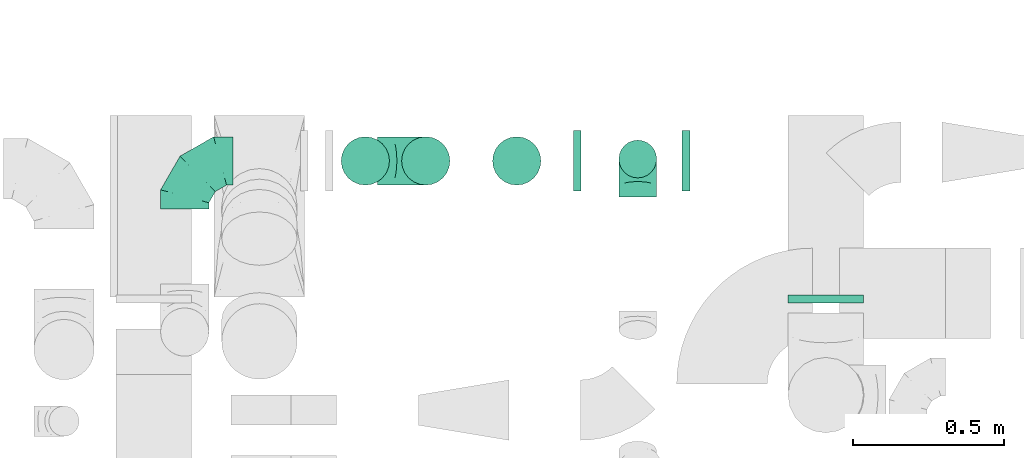
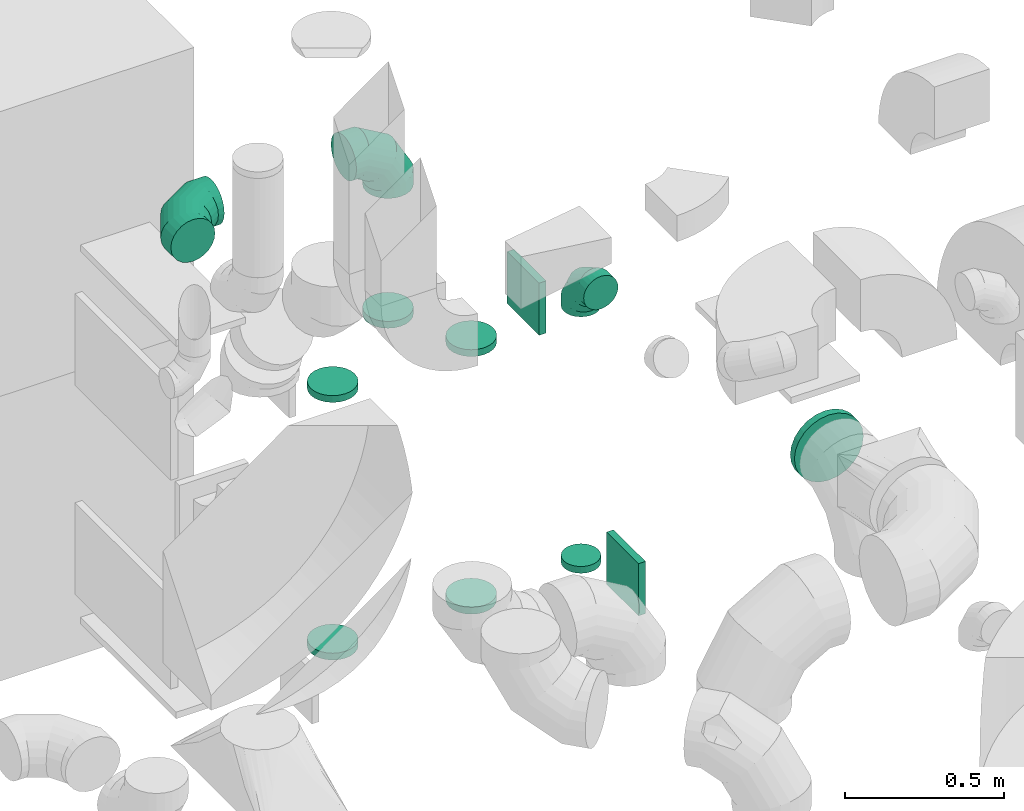
# One storey, part 29 of 59: 12 flow fittings.
"""IFC2X3 building model written with IfcOpenShell, lengths in millimetres."""

from ifc_helpers import new_model, entity, si_unit, converted_unit, derived_unit, direction, frame, origin, origin_2d_with_axis, place, context, subcontext, project, spatial, rectangle, extrude, faceted_brep, source, transform, mapped, material, type_object, type_shapes, element, save


model = new_model("IFC2X3")

# Units and contexts
model_context = context("Model", 3, precision=0.01, world=origin(), true_north=direction((6.12303176911189e-17, 1.0)))
body_context = subcontext(model_context, "Body", "Model", "MODEL_VIEW")
ifc_project = project(units=[si_unit("LENGTHUNIT", "METRE", prefix="MILLI"), si_unit("AREAUNIT", "SQUARE_METRE"), si_unit("VOLUMEUNIT", "CUBIC_METRE"), converted_unit("PLANEANGLEUNIT", "DEGREE", entity("IfcRatioMeasure", 0.0174532925199433), si_unit("PLANEANGLEUNIT", "RADIAN"), dimensions=[0, 0, 0, 0, 0, 0, 0]), si_unit("MASSUNIT", "GRAM", prefix="KILO"), derived_unit("MASSDENSITYUNIT", [(si_unit("MASSUNIT", "GRAM", prefix="KILO"), 1), (si_unit("LENGTHUNIT", "METRE"), -3)]), derived_unit("MOMENTOFINERTIAUNIT", [(si_unit("LENGTHUNIT", "METRE"), 4)]), si_unit("TIMEUNIT", "SECOND"), si_unit("FREQUENCYUNIT", "HERTZ"), si_unit("THERMODYNAMICTEMPERATUREUNIT", "DEGREE_CELSIUS"), derived_unit("THERMALTRANSMITTANCEUNIT", [(si_unit("MASSUNIT", "GRAM", prefix="KILO"), 1), (si_unit("THERMODYNAMICTEMPERATUREUNIT", "KELVIN"), -1), (si_unit("TIMEUNIT", "SECOND"), -3)]), derived_unit("VOLUMETRICFLOWRATEUNIT", [(si_unit("LENGTHUNIT", "METRE"), 3), (si_unit("TIMEUNIT", "SECOND"), -1)]), derived_unit("MASSFLOWRATEUNIT", [(si_unit("MASSUNIT", "GRAM", prefix="KILO"), 1), (si_unit("TIMEUNIT", "SECOND"), -1)]), derived_unit("ROTATIONALFREQUENCYUNIT", [(si_unit("TIMEUNIT", "SECOND"), -1)]), si_unit("ELECTRICCURRENTUNIT", "AMPERE"), si_unit("ELECTRICVOLTAGEUNIT", "VOLT"), si_unit("POWERUNIT", "WATT"), si_unit("FORCEUNIT", "NEWTON", prefix="KILO"), si_unit("ILLUMINANCEUNIT", "LUX"), si_unit("LUMINOUSFLUXUNIT", "LUMEN"), si_unit("LUMINOUSINTENSITYUNIT", "CANDELA"), derived_unit("USERDEFINED", [(si_unit("MASSUNIT", "GRAM", prefix="KILO"), -1), (si_unit("LENGTHUNIT", "METRE"), -2), (si_unit("TIMEUNIT", "SECOND"), 3), (si_unit("LUMINOUSFLUXUNIT", "LUMEN"), 1)]), derived_unit("LINEARVELOCITYUNIT", [(si_unit("LENGTHUNIT", "METRE"), 1), (si_unit("TIMEUNIT", "SECOND"), -1)]), si_unit("PRESSUREUNIT", "PASCAL"), derived_unit("USERDEFINED", [(si_unit("LENGTHUNIT", "METRE"), -2), (si_unit("MASSUNIT", "GRAM", prefix="KILO"), 1), (si_unit("TIMEUNIT", "SECOND"), -2)]), derived_unit("LINEARFORCEUNIT", [(si_unit("MASSUNIT", "GRAM", prefix="KILO"), 1), (si_unit("LENGTHUNIT", "METRE"), 1), (si_unit("TIMEUNIT", "SECOND"), -2), (si_unit("LENGTHUNIT", "METRE"), -1)]), derived_unit("PLANARFORCEUNIT", [(si_unit("MASSUNIT", "GRAM", prefix="KILO"), 1), (si_unit("LENGTHUNIT", "METRE"), 1), (si_unit("TIMEUNIT", "SECOND"), -2), (si_unit("LENGTHUNIT", "METRE"), -2)])], contexts=[model_context])

# Site, building, storey
site_placement = place(None, origin())
site = spatial("IfcSite", under=ifc_project, at=site_placement, CompositionType="ELEMENT")
building_placement = place(site_placement, origin())
building = spatial("IfcBuilding", under=site, at=building_placement, CompositionType="ELEMENT")
storey_placement = place(building_placement, frame((0.0, 0.0, 28200.0)))
storey = spatial("IfcBuildingStorey", under=building, at=storey_placement, CompositionType="ELEMENT", Elevation=28200.0)

# Flow fittings
ifc_material = material()
duct_fitting_type_1 = type_object("IfcDuctFittingType", PredefinedType="NOTDEFINED", material=ifc_material)
shared_shape_1 = source(origin(), body_context, "Body", "SweptSolid", [
    extrude(rectangle(XDim=24.9999999999999, YDim=200.0, at=origin_2d_with_axis()), frame((12.5, 0.0, -100.0)), (0.0, 0.0, 1.0), 200.0),
])
type_shapes(duct_fitting_type_1, [shared_shape_1])
for number, where in (
    (1, (50418.28, 13024.99, 1699.32)),
    (2, (50058.28, 13024.99, 2899.32)),
):
    element("IfcFlowFitting", number, at=place(storey_placement, frame(where)), inside=storey, type_object=duct_fitting_type_1, material=ifc_material, context=body_context, shape_type="MappedRepresentation", body=[
        mapped(shared_shape_1, transform((0.0, 0.0, 0.0), scale=1.0)),
    ])
duct_fitting_type_2 = type_object("IfcDuctFittingType", PredefinedType="NOTDEFINED", material=ifc_material)
shared_shape_2 = source(origin(), body_context, "Body", "Brep", [
    faceted_brep([(-160.0, 0.0, -80.0), (-160.0, -20.71, -77.27), (-160.0, -40.0, -69.28), (-160.0, -56.57, -56.57), (-160.0, -69.28, -40.0), (-160.0, -77.27, -20.71), (-160.0, -80.0, 0.0), (-160.0, -77.27, 20.71), (-160.0, -69.28, 40.0), (-160.0, -56.57, 56.57), (-160.0, -40.0, 69.28), (-160.0, -20.71, 77.27), (-160.0, 0.0, 80.0), (-160.0, 20.71, 77.27), (-160.0, 40.0, 69.28), (-160.0, 56.57, 56.57), (-160.0, 69.28, 40.0), (-160.0, 77.27, 20.71), (-160.0, 80.0, 0.0), (-160.0, 77.27, -20.71), (-160.0, 69.28, -40.0), (-160.0, 56.57, -56.57), (-160.0, 40.0, -69.28), (-160.0, 20.71, -77.27), (-122.68, 20.71, 77.27), (-127.85, 40.0, 69.28), (-117.13, 0.0, 80.0), (-132.29, 56.57, 56.57), (-137.83, 77.27, 20.71), (-138.56, 80.0, 0.0), (-135.69, 69.28, 40.0), (-135.69, 69.28, -40.0), (-132.29, 56.57, -56.57), (-137.83, 77.27, -20.71), (-122.68, 20.71, -77.27), (-117.13, 0.0, -80.0), (-127.85, 40.0, -69.28), (-111.58, -20.71, -77.27), (-106.41, -40.0, -69.28), (-101.97, -56.57, -56.57), (-98.56, -69.28, -40.0), (-96.42, -77.27, -20.71), (-95.69, -80.0, 0.0), (-96.42, -77.27, 20.71), (-98.56, -69.28, 40.0), (-101.97, -56.57, 56.57), (-106.41, -40.0, 69.28), (-111.58, -20.71, 77.27), (-58.03, 58.03, 77.27), (-72.15, 72.15, 69.28), (-42.87, 42.87, 80.0), (-84.28, 84.28, 56.57), (-93.59, 93.59, 40.0), (-99.44, 99.44, 20.71), (-101.44, 101.44, 0.0), (-99.44, 99.44, -20.71), (-93.59, 93.59, -40.0), (-84.28, 84.28, -56.57), (-58.03, 58.03, -77.27), (-42.87, 42.87, -80.0), (-72.15, 72.15, -69.28), (-27.71, 27.71, -77.27), (-13.59, 13.59, -69.28), (-1.46, 1.46, -56.57), (7.85, -7.85, -40.0), (13.7, -13.7, -20.71), (15.69, -15.69, 0.0), (13.7, -13.7, 20.71), (7.85, -7.85, 40.0), (-1.46, 1.46, 56.57), (-13.59, 13.59, 69.28), (-27.71, 27.71, 77.27), (-20.71, 122.68, 77.27), (-40.0, 127.85, 69.28), (0.0, 117.13, 80.0), (-56.57, 132.29, 56.57), (-69.28, 135.69, 40.0), (-77.27, 137.83, 20.71), (-80.0, 138.56, 0.0), (-77.27, 137.83, -20.71), (-69.28, 135.69, -40.0), (-56.57, 132.29, -56.57), (-20.71, 122.68, -77.27), (0.0, 117.13, -80.0), (-40.0, 127.85, -69.28), (20.71, 111.58, -77.27), (40.0, 106.41, -69.28), (56.57, 101.97, -56.57), (69.28, 98.56, -40.0), (77.27, 96.42, -20.71), (80.0, 95.69, 0.0), (77.27, 96.42, 20.71), (69.28, 98.56, 40.0), (56.57, 101.97, 56.57), (40.0, 106.41, 69.28), (20.71, 111.58, 77.27), (-20.71, 160.0, -77.27), (-40.0, 160.0, -69.28), (-56.57, 160.0, -56.57), (-69.28, 160.0, -40.0), (-77.27, 160.0, -20.71), (-80.0, 160.0, 0.0), (-77.27, 160.0, 20.71), (-69.28, 160.0, 40.0), (-56.57, 160.0, 56.57), (-40.0, 160.0, 69.28), (-20.71, 160.0, 77.27), (0.0, 160.0, 80.0), (20.71, 160.0, 77.27), (40.0, 160.0, 69.28), (56.57, 160.0, 56.57), (69.28, 160.0, 40.0), (77.27, 160.0, 20.71), (80.0, 160.0, 0.0), (77.27, 160.0, -20.71), (69.28, 160.0, -40.0), (56.57, 160.0, -56.57), (40.0, 160.0, -69.28), (20.71, 160.0, -77.27), (0.0, 160.0, -80.0)], [[[0, 1, 2, 3, 4, 5, 6, 7, 8, 9, 10, 11, 12, 13, 14, 15, 16, 17, 18, 19, 20, 21, 22, 23]], [[24, 25, 14, 13]], [[26, 24, 13, 12]], [[14, 25, 27, 15]], [[28, 29, 18, 17]], [[30, 28, 17, 16]], [[15, 27, 30, 16]], [[20, 31, 32, 21]], [[33, 31, 20, 19]], [[18, 29, 33, 19]], [[34, 35, 0, 23]], [[36, 34, 23, 22]], [[32, 36, 22, 21]], [[1, 0, 35, 37]], [[2, 1, 37, 38]], [[3, 2, 38, 39]], [[5, 4, 40, 41]], [[6, 5, 41, 42]], [[39, 40, 4, 3]], [[6, 42, 43, 7]], [[7, 43, 44, 8]], [[8, 44, 45, 9]], [[9, 45, 46, 10]], [[10, 46, 47, 11]], [[26, 12, 11, 47]], [[48, 49, 25, 24]], [[50, 48, 24, 26]], [[27, 25, 49, 51]], [[52, 53, 28, 30]], [[51, 52, 30, 27]], [[29, 28, 53, 54]], [[55, 56, 31, 33]], [[54, 55, 33, 29]], [[32, 31, 56, 57]], [[58, 59, 35, 34]], [[60, 58, 34, 36]], [[57, 60, 36, 32]], [[37, 35, 59, 61]], [[38, 37, 61, 62]], [[39, 38, 62, 63]], [[41, 40, 64, 65]], [[42, 41, 65, 66]], [[63, 64, 40, 39]], [[43, 42, 66, 67]], [[44, 43, 67, 68]], [[68, 69, 45, 44]], [[46, 45, 69, 70]], [[47, 46, 70, 71]], [[26, 47, 71, 50]], [[72, 73, 49, 48]], [[74, 72, 48, 50]], [[51, 49, 73, 75]], [[76, 77, 53, 52]], [[75, 76, 52, 51]], [[54, 53, 77, 78]], [[79, 80, 56, 55]], [[78, 79, 55, 54]], [[57, 56, 80, 81]], [[82, 83, 59, 58]], [[84, 82, 58, 60]], [[81, 84, 60, 57]], [[61, 59, 83, 85]], [[62, 61, 85, 86]], [[63, 62, 86, 87]], [[65, 64, 88, 89]], [[66, 65, 89, 90]], [[87, 88, 64, 63]], [[67, 66, 90, 91]], [[68, 67, 91, 92]], [[92, 93, 69, 68]], [[70, 69, 93, 94]], [[71, 70, 94, 95]], [[50, 71, 95, 74]], [[96, 97, 98, 99, 100, 101, 102, 103, 104, 105, 106, 107, 108, 109, 110, 111, 112, 113, 114, 115, 116, 117, 118, 119]], [[72, 74, 107, 106]], [[73, 72, 106, 105]], [[75, 73, 105, 104]], [[77, 76, 103, 102]], [[78, 77, 102, 101]], [[75, 104, 103, 76]], [[78, 101, 100, 79]], [[79, 100, 99, 80]], [[80, 99, 98, 81]], [[84, 97, 96, 82]], [[82, 96, 119, 83]], [[84, 81, 98, 97]], [[118, 117, 86, 85]], [[119, 118, 85, 83]], [[116, 87, 86, 117]], [[88, 115, 114, 89]], [[89, 114, 113, 90]], [[115, 88, 87, 116]], [[112, 111, 92, 91]], [[113, 112, 91, 90]], [[111, 110, 93, 92]], [[95, 94, 109, 108]], [[74, 95, 108, 107]], [[110, 109, 94, 93]]]),
])
type_shapes(duct_fitting_type_2, [shared_shape_2])
for number, where, z_axis, x_axis in (
    (3, (49568.63, 13024.99, 3650.0), (0.0, -1.0, 0.0), (0.0, 0.0, 1.0)),
    (4, (48770.09, 13024.99, 3650.0), (0.0, 0.0, 1.0), (-1.0, 0.0, 0.0)),
):
    element("IfcFlowFitting", number, at=place(storey_placement, frame(where, z_axis=z_axis, x_axis=x_axis)), inside=storey, type_object=duct_fitting_type_2, material=ifc_material, context=body_context, shape_type="MappedRepresentation", body=[
        mapped(shared_shape_2, transform((0.0, 0.0, 0.0), scale=1.0)),
    ])
duct_fitting_type_3 = type_object("IfcDuctFittingType", PredefinedType="NOTDEFINED", material=ifc_material)
shared_shape_3 = source(origin(), body_context, "Body", "Brep", [
    faceted_brep([(20.0, 0.0, -125.0), (20.0, 32.35, -120.74), (20.0, 62.5, -108.25), (20.0, 88.39, -88.39), (20.0, 108.25, -62.5), (20.0, 120.74, -32.35), (20.0, 125.0, 0.0), (20.0, 120.74, 32.35), (20.0, 108.25, 62.5), (20.0, 88.39, 88.39), (20.0, 62.5, 108.25), (20.0, 32.35, 120.74), (20.0, 0.0, 125.0), (20.0, -32.35, 120.74), (20.0, -62.5, 108.25), (20.0, -88.39, 88.39), (20.0, -108.25, 62.5), (20.0, -120.74, 32.35), (20.0, -125.0, 0.0), (20.0, -120.74, -32.35), (20.0, -108.25, -62.5), (20.0, -88.39, -88.39), (20.0, -62.5, -108.25), (20.0, -32.35, -120.74), (0.0, 0.0, 125.0), (-6.1, 0.0, 125.0), (-6.1, -32.35, 120.74), (0.0, -32.35, 120.74), (-6.1, -62.5, 108.25), (0.0, -62.5, 108.25), (0.0, -88.39, 88.39), (-6.1, -88.39, 88.39), (0.0, -108.25, 62.5), (-6.1, -108.25, 62.5), (-6.1, -120.74, 32.35), (0.0, -120.74, 32.35), (-6.1, -125.0, 0.0), (0.0, -125.0, 0.0), (-6.1, -120.74, -32.35), (0.0, -120.74, -32.35), (-6.1, -108.25, -62.5), (0.0, -108.25, -62.5), (0.0, -88.39, -88.39), (-6.1, -88.39, -88.39), (0.0, -62.5, -108.25), (-6.1, -62.5, -108.25), (-6.1, -32.35, -120.74), (0.0, -32.35, -120.74), (-6.1, 0.0, -125.0), (0.0, 0.0, -125.0), (-6.1, 32.35, -120.74), (0.0, 32.35, -120.74), (-6.1, 62.5, -108.25), (0.0, 62.5, -108.25), (0.0, 88.39, -88.39), (-6.1, 88.39, -88.39), (0.0, 108.25, -62.5), (-6.1, 108.25, -62.5), (-6.1, 120.74, -32.35), (0.0, 120.74, -32.35), (-6.1, 125.0, 0.0), (0.0, 125.0, 0.0), (-6.1, 120.74, 32.35), (0.0, 120.74, 32.35), (-6.1, 108.25, 62.5), (0.0, 108.25, 62.5), (0.0, 88.39, 88.39), (-6.1, 88.39, 88.39), (0.0, 62.5, 108.25), (-6.1, 62.5, 108.25), (-6.1, 32.35, 120.74), (0.0, 32.35, 120.74)], [[[0, 1, 2, 3, 4, 5, 6, 7, 8, 9, 10, 11, 12, 13, 14, 15, 16, 17, 18, 19, 20, 21, 22, 23]], [[13, 12, 24, 25, 26, 27]], [[14, 13, 27, 26, 28, 29]], [[30, 15, 14, 29, 28, 31]], [[17, 16, 32, 33, 34, 35]], [[18, 17, 35, 34, 36, 37]], [[32, 16, 15, 30, 31, 33]], [[19, 18, 37, 36, 38, 39]], [[20, 19, 39, 38, 40, 41]], [[42, 21, 20, 41, 40, 43]], [[23, 22, 44, 45, 46, 47]], [[0, 23, 47, 46, 48, 49]], [[44, 22, 21, 42, 43, 45]], [[1, 0, 49, 48, 50, 51]], [[2, 1, 51, 50, 52, 53]], [[54, 3, 2, 53, 52, 55]], [[5, 4, 56, 57, 58, 59]], [[6, 5, 59, 58, 60, 61]], [[56, 4, 3, 54, 55, 57]], [[7, 6, 61, 60, 62, 63]], [[8, 7, 63, 62, 64, 65]], [[66, 9, 8, 65, 64, 67]], [[11, 10, 68, 69, 70, 71]], [[12, 11, 71, 70, 25, 24]], [[68, 10, 9, 66, 67, 69]], [[46, 45, 43, 40, 38, 36, 34, 33, 31, 28, 26, 25, 70, 69, 67, 64, 62, 60, 58, 57, 55, 52, 50, 48]]]),
])
type_shapes(duct_fitting_type_3, [shared_shape_3])
flow_fitting_1_placement = place(storey_placement, frame((50893.68, 12574.75, 2302.02), z_axis=(-1.0, 0.0, 0.0), x_axis=(0.0, -1.0, 0.0)))
element("IfcFlowFitting", 5, at=flow_fitting_1_placement, inside=storey, type_object=duct_fitting_type_3, material=ifc_material, context=body_context, shape_type="MappedRepresentation", body=[
    mapped(shared_shape_3, transform((0.0, 0.0, 0.0), scale=1.0)),
])
duct_fitting_type_4 = type_object("IfcDuctFittingType", PredefinedType="NOTDEFINED", material=ifc_material)
shared_shape_4 = source(origin(), body_context, "Body", "Brep", [
    faceted_brep([(-125.0, 0.0, -62.5), (-125.0, -16.18, -60.37), (-125.0, -31.25, -54.13), (-125.0, -44.19, -44.19), (-125.0, -54.13, -31.25), (-125.0, -60.37, -16.18), (-125.0, -62.5, 0.0), (-125.0, -60.37, 16.18), (-125.0, -54.13, 31.25), (-125.0, -44.19, 44.19), (-125.0, -31.25, 54.13), (-125.0, -16.18, 60.37), (-125.0, 0.0, 62.5), (-125.0, 16.18, 60.37), (-125.0, 31.25, 54.13), (-125.0, 44.19, 44.19), (-125.0, 54.13, 31.25), (-125.0, 60.37, 16.18), (-125.0, 62.5, 0.0), (-125.0, 60.37, -16.18), (-125.0, 54.13, -31.25), (-125.0, 44.19, -44.19), (-125.0, 31.25, -54.13), (-125.0, 16.18, -60.37), (-95.84, 16.18, 60.37), (-99.88, 31.25, 54.13), (-91.51, 0.0, 62.5), (-103.35, 44.19, 44.19), (-107.68, 60.37, 16.18), (-108.25, 62.5, 0.0), (-106.01, 54.13, 31.25), (-106.01, 54.13, -31.25), (-103.35, 44.19, -44.19), (-107.68, 60.37, -16.18), (-95.84, 16.18, -60.37), (-91.51, 0.0, -62.5), (-99.88, 31.25, -54.13), (-87.17, -16.18, -60.37), (-83.13, -31.25, -54.13), (-79.66, -44.19, -44.19), (-77.0, -54.13, -31.25), (-75.33, -60.37, -16.18), (-74.76, -62.5, 0.0), (-75.33, -60.37, 16.18), (-77.0, -54.13, 31.25), (-79.66, -44.19, 44.19), (-83.13, -31.25, 54.13), (-87.17, -16.18, 60.37), (-45.34, 45.34, 60.37), (-56.37, 56.37, 54.13), (-33.49, 33.49, 62.5), (-65.85, 65.85, 44.19), (-73.12, 73.12, 31.25), (-77.69, 77.69, 16.18), (-79.25, 79.25, 0.0), (-77.69, 77.69, -16.18), (-73.12, 73.12, -31.25), (-65.85, 65.85, -44.19), (-45.34, 45.34, -60.37), (-33.49, 33.49, -62.5), (-56.37, 56.37, -54.13), (-21.65, 21.65, -60.37), (-10.62, 10.62, -54.13), (-1.14, 1.14, -44.19), (6.13, -6.13, -31.25), (10.7, -10.7, -16.18), (12.26, -12.26, 0.0), (10.7, -10.7, 16.18), (6.13, -6.13, 31.25), (-1.14, 1.14, 44.19), (-10.62, 10.62, 54.13), (-21.65, 21.65, 60.37), (-16.18, 95.84, 60.37), (-31.25, 99.88, 54.13), (0.0, 91.51, 62.5), (-44.19, 103.35, 44.19), (-54.13, 106.01, 31.25), (-60.37, 107.68, 16.18), (-62.5, 108.25, 0.0), (-60.37, 107.68, -16.18), (-54.13, 106.01, -31.25), (-44.19, 103.35, -44.19), (-16.18, 95.84, -60.37), (0.0, 91.51, -62.5), (-31.25, 99.88, -54.13), (16.18, 87.17, -60.37), (31.25, 83.13, -54.13), (44.19, 79.66, -44.19), (54.13, 77.0, -31.25), (60.37, 75.33, -16.18), (62.5, 74.76, 0.0), (60.37, 75.33, 16.18), (54.13, 77.0, 31.25), (44.19, 79.66, 44.19), (31.25, 83.13, 54.13), (16.18, 87.17, 60.37), (-16.18, 125.0, -60.37), (-31.25, 125.0, -54.13), (-44.19, 125.0, -44.19), (-54.13, 125.0, -31.25), (-60.37, 125.0, -16.18), (-62.5, 125.0, 0.0), (-60.37, 125.0, 16.18), (-54.13, 125.0, 31.25), (-44.19, 125.0, 44.19), (-31.25, 125.0, 54.13), (-16.18, 125.0, 60.37), (0.0, 125.0, 62.5), (16.18, 125.0, 60.37), (31.25, 125.0, 54.13), (44.19, 125.0, 44.19), (54.13, 125.0, 31.25), (60.37, 125.0, 16.18), (62.5, 125.0, 0.0), (60.37, 125.0, -16.18), (54.13, 125.0, -31.25), (44.19, 125.0, -44.19), (31.25, 125.0, -54.13), (16.18, 125.0, -60.37), (0.0, 125.0, -62.5)], [[[0, 1, 2, 3, 4, 5, 6, 7, 8, 9, 10, 11, 12, 13, 14, 15, 16, 17, 18, 19, 20, 21, 22, 23]], [[24, 25, 14, 13]], [[26, 24, 13, 12]], [[14, 25, 27, 15]], [[28, 29, 18, 17]], [[30, 28, 17, 16]], [[15, 27, 30, 16]], [[20, 31, 32, 21]], [[33, 31, 20, 19]], [[18, 29, 33, 19]], [[34, 35, 0, 23]], [[36, 34, 23, 22]], [[21, 32, 36, 22]], [[1, 0, 35, 37]], [[2, 1, 37, 38]], [[38, 39, 3, 2]], [[5, 4, 40, 41]], [[6, 5, 41, 42]], [[39, 40, 4, 3]], [[6, 42, 43, 7]], [[7, 43, 44, 8]], [[45, 9, 8, 44]], [[9, 45, 46, 10]], [[10, 46, 47, 11]], [[26, 12, 11, 47]], [[48, 49, 25, 24]], [[50, 48, 24, 26]], [[27, 25, 49, 51]], [[52, 53, 28, 30]], [[51, 52, 30, 27]], [[29, 28, 53, 54]], [[55, 56, 31, 33]], [[54, 55, 33, 29]], [[57, 32, 31, 56]], [[58, 59, 35, 34]], [[60, 58, 34, 36]], [[57, 60, 36, 32]], [[37, 35, 59, 61]], [[38, 37, 61, 62]], [[39, 38, 62, 63]], [[41, 40, 64, 65]], [[42, 41, 65, 66]], [[63, 64, 40, 39]], [[43, 42, 66, 67]], [[44, 43, 67, 68]], [[68, 69, 45, 44]], [[46, 45, 69, 70]], [[47, 46, 70, 71]], [[26, 47, 71, 50]], [[72, 73, 49, 48]], [[74, 72, 48, 50]], [[51, 49, 73, 75]], [[76, 77, 53, 52]], [[75, 76, 52, 51]], [[54, 53, 77, 78]], [[79, 80, 56, 55]], [[78, 79, 55, 54]], [[81, 57, 56, 80]], [[82, 83, 59, 58]], [[84, 82, 58, 60]], [[81, 84, 60, 57]], [[61, 59, 83, 85]], [[62, 61, 85, 86]], [[63, 62, 86, 87]], [[65, 64, 88, 89]], [[66, 65, 89, 90]], [[87, 88, 64, 63]], [[67, 66, 90, 91]], [[68, 67, 91, 92]], [[92, 93, 69, 68]], [[70, 69, 93, 94]], [[71, 70, 94, 95]], [[50, 71, 95, 74]], [[96, 97, 98, 99, 100, 101, 102, 103, 104, 105, 106, 107, 108, 109, 110, 111, 112, 113, 114, 115, 116, 117, 118, 119]], [[72, 74, 107, 106]], [[73, 72, 106, 105]], [[75, 73, 105, 104]], [[77, 76, 103, 102]], [[78, 77, 102, 101]], [[75, 104, 103, 76]], [[78, 101, 100, 79]], [[79, 100, 99, 80]], [[80, 99, 98, 81]], [[96, 119, 83, 82]], [[97, 96, 82, 84]], [[84, 81, 98, 97]], [[83, 119, 118, 85]], [[85, 118, 117, 86]], [[116, 87, 86, 117]], [[88, 115, 114, 89]], [[89, 114, 113, 90]], [[115, 88, 87, 116]], [[91, 90, 113, 112]], [[92, 91, 112, 111]], [[111, 110, 93, 92]], [[95, 94, 109, 108]], [[74, 95, 108, 107]], [[110, 109, 94, 93]]]),
])
type_shapes(duct_fitting_type_4, [shared_shape_4])
flow_fitting_2_placement = place(storey_placement, frame((50271.02, 13031.27, 2900.0), z_axis=(-1.0, 0.0, 0.0), x_axis=(0.0, 1.0, 0.0)))
element("IfcFlowFitting", 6, at=flow_fitting_2_placement, inside=storey, type_object=duct_fitting_type_4, material=ifc_material, context=body_context, shape_type="MappedRepresentation", body=[
    mapped(shared_shape_4, transform((0.0, 0.0, 0.0), scale=1.0)),
])
duct_fitting_type_5 = type_object("IfcDuctFittingType", PredefinedType="NOTDEFINED", material=ifc_material)
shared_shape_5 = source(origin(), body_context, "Body", "Brep", [
    faceted_brep([(20.0, 0.0, -80.0), (20.0, 20.71, -77.27), (20.0, 40.0, -69.28), (20.0, 56.57, -56.57), (20.0, 69.28, -40.0), (20.0, 77.27, -20.71), (20.0, 80.0, 0.0), (20.0, 77.27, 20.71), (20.0, 69.28, 40.0), (20.0, 56.57, 56.57), (20.0, 40.0, 69.28), (20.0, 20.71, 77.27), (20.0, 0.0, 80.0), (20.0, -20.71, 77.27), (20.0, -40.0, 69.28), (20.0, -56.57, 56.57), (20.0, -69.28, 40.0), (20.0, -77.27, 20.71), (20.0, -80.0, 0.0), (20.0, -77.27, -20.71), (20.0, -69.28, -40.0), (20.0, -56.57, -56.57), (20.0, -40.0, -69.28), (20.0, -20.71, -77.27), (0.0, 0.0, 80.0), (-6.1, 0.0, 80.0), (-6.1, -20.71, 77.27), (0.0, -20.71, 77.27), (-6.1, -40.0, 69.28), (0.0, -40.0, 69.28), (0.0, -56.57, 56.57), (-6.1, -56.57, 56.57), (0.0, -69.28, 40.0), (-6.1, -69.28, 40.0), (-6.1, -77.27, 20.71), (0.0, -77.27, 20.71), (-6.1, -80.0, 0.0), (0.0, -80.0, 0.0), (-6.1, -77.27, -20.71), (0.0, -77.27, -20.71), (-6.1, -69.28, -40.0), (0.0, -69.28, -40.0), (0.0, -56.57, -56.57), (-6.1, -56.57, -56.57), (0.0, -40.0, -69.28), (-6.1, -40.0, -69.28), (-6.1, -20.71, -77.27), (0.0, -20.71, -77.27), (-6.1, 0.0, -80.0), (0.0, 0.0, -80.0), (-6.1, 20.71, -77.27), (0.0, 20.71, -77.27), (-6.1, 40.0, -69.28), (0.0, 40.0, -69.28), (0.0, 56.57, -56.57), (-6.1, 56.57, -56.57), (0.0, 69.28, -40.0), (-6.1, 69.28, -40.0), (-6.1, 77.27, -20.71), (0.0, 77.27, -20.71), (-6.1, 80.0, 0.0), (0.0, 80.0, 0.0), (-6.1, 77.27, 20.71), (0.0, 77.27, 20.71), (-6.1, 69.28, 40.0), (0.0, 69.28, 40.0), (0.0, 56.57, 56.57), (-6.1, 56.57, 56.57), (0.0, 40.0, 69.28), (-6.1, 40.0, 69.28), (-6.1, 20.71, 77.27), (0.0, 20.71, 77.27)], [[[0, 1, 2, 3, 4, 5, 6, 7, 8, 9, 10, 11, 12, 13, 14, 15, 16, 17, 18, 19, 20, 21, 22, 23]], [[13, 12, 24, 25, 26, 27]], [[14, 13, 27, 26, 28, 29]], [[30, 15, 14, 29, 28, 31]], [[17, 16, 32, 33, 34, 35]], [[18, 17, 35, 34, 36, 37]], [[32, 16, 15, 30, 31, 33]], [[19, 18, 37, 36, 38, 39]], [[20, 19, 39, 38, 40, 41]], [[42, 21, 20, 41, 40, 43]], [[23, 22, 44, 45, 46, 47]], [[0, 23, 47, 46, 48, 49]], [[44, 22, 21, 42, 43, 45]], [[1, 0, 49, 48, 50, 51]], [[2, 1, 51, 50, 52, 53]], [[54, 3, 2, 53, 52, 55]], [[5, 4, 56, 57, 58, 59]], [[6, 5, 59, 58, 60, 61]], [[56, 4, 3, 54, 55, 57]], [[7, 6, 61, 60, 62, 63]], [[8, 7, 63, 62, 64, 65]], [[66, 9, 8, 65, 64, 67]], [[11, 10, 68, 69, 70, 71]], [[12, 11, 71, 70, 25, 24]], [[68, 10, 9, 66, 67, 69]], [[46, 45, 43, 40, 38, 36, 34, 33, 31, 28, 26, 25, 70, 69, 67, 64, 62, 60, 58, 57, 55, 52, 50, 48]]]),
])
type_shapes(duct_fitting_type_5, [shared_shape_5])
for number, where, z_axis, x_axis in (
    (7, (49368.47, 13024.99, 2799.32), (0.0, 1.0, 0.0), (0.0, 0.0, -1.0)),
    (8, (49870.11, 13024.99, 2799.32), (0.0, 1.0, 0.0), (0.0, 0.0, -1.0)),
):
    element("IfcFlowFitting", number, at=place(storey_placement, frame(where, z_axis=z_axis, x_axis=x_axis)), inside=storey, type_object=duct_fitting_type_5, material=ifc_material, context=body_context, shape_type="MappedRepresentation", body=[
        mapped(shared_shape_5, transform((0.0, 0.0, 0.0), scale=1.0)),
    ])
duct_fitting_type_6 = type_object("IfcDuctFittingType", PredefinedType="NOTDEFINED", material=ifc_material)
shared_shape_6 = source(origin(), body_context, "Body", "Brep", [
    faceted_brep([(20.0, 16.18, -60.37), (20.0, 31.25, -54.13), (20.0, 44.19, -44.19), (20.0, 54.13, -31.25), (20.0, 60.37, -16.18), (20.0, 62.5, 0.0), (20.0, 60.37, 16.18), (20.0, 54.13, 31.25), (20.0, 44.19, 44.19), (20.0, 31.25, 54.13), (20.0, 16.18, 60.37), (20.0, 0.0, 62.5), (20.0, -16.18, 60.37), (20.0, -31.25, 54.13), (20.0, -44.19, 44.19), (20.0, -54.13, 31.25), (20.0, -60.37, 16.18), (20.0, -62.5, 0.0), (20.0, -60.37, -16.18), (20.0, -54.13, -31.25), (20.0, -44.19, -44.19), (20.0, -31.25, -54.13), (20.0, -16.18, -60.37), (20.0, 0.0, -62.5), (0.0, 0.0, 62.5), (0.0, 16.18, 60.37), (-6.1, 16.18, 60.37), (-6.1, 0.0, 62.5), (0.0, 31.25, 54.13), (-6.1, 31.25, 54.13), (0.0, 44.19, 44.19), (-6.1, 44.19, 44.19), (0.0, 54.13, 31.25), (0.0, 60.37, 16.18), (-6.1, 60.37, 16.18), (-6.1, 54.13, 31.25), (0.0, 62.5, 0.0), (-6.1, 62.5, 0.0), (0.0, 60.37, -16.18), (-6.1, 60.37, -16.18), (0.0, 54.13, -31.25), (-6.1, 54.13, -31.25), (0.0, 44.19, -44.19), (-6.1, 44.19, -44.19), (0.0, 31.25, -54.13), (0.0, 16.18, -60.37), (-6.1, 16.18, -60.37), (-6.1, 31.25, -54.13), (0.0, 0.0, -62.5), (-6.1, 0.0, -62.5), (0.0, -16.18, -60.37), (-6.1, -16.18, -60.37), (0.0, -31.25, -54.13), (-6.1, -31.25, -54.13), (0.0, -44.19, -44.19), (-6.1, -44.19, -44.19), (0.0, -54.13, -31.25), (0.0, -60.37, -16.18), (-6.1, -60.37, -16.18), (-6.1, -54.13, -31.25), (0.0, -62.5, 0.0), (-6.1, -62.5, 0.0), (0.0, -60.37, 16.18), (-6.1, -60.37, 16.18), (0.0, -54.13, 31.25), (-6.1, -54.13, 31.25), (0.0, -44.19, 44.19), (-6.1, -44.19, 44.19), (0.0, -31.25, 54.13), (0.0, -16.18, 60.37), (-6.1, -16.18, 60.37), (-6.1, -31.25, 54.13)], [[[0, 1, 2, 3, 4, 5, 6, 7, 8, 9, 10, 11, 12, 13, 14, 15, 16, 17, 18, 19, 20, 21, 22, 23]], [[24, 11, 10, 25, 26, 27]], [[25, 10, 9, 28, 29, 26]], [[28, 9, 8, 30, 31, 29]], [[32, 7, 6, 33, 34, 35]], [[33, 6, 5, 36, 37, 34]], [[30, 8, 7, 32, 35, 31]], [[36, 5, 4, 38, 39, 37]], [[38, 4, 3, 40, 41, 39]], [[40, 3, 2, 42, 43, 41]], [[44, 1, 0, 45, 46, 47]], [[45, 0, 23, 48, 49, 46]], [[42, 2, 1, 44, 47, 43]], [[48, 23, 22, 50, 51, 49]], [[50, 22, 21, 52, 53, 51]], [[52, 21, 20, 54, 55, 53]], [[56, 19, 18, 57, 58, 59]], [[57, 18, 17, 60, 61, 58]], [[54, 20, 19, 56, 59, 55]], [[60, 17, 16, 62, 63, 61]], [[62, 16, 15, 64, 65, 63]], [[64, 15, 14, 66, 67, 65]], [[68, 13, 12, 69, 70, 71]], [[69, 12, 11, 24, 27, 70]], [[66, 14, 13, 68, 71, 67]], [[49, 51, 53, 55, 59, 58, 61, 63, 65, 67, 71, 70, 27, 26, 29, 31, 35, 34, 37, 39, 41, 43, 47, 46]]]),
])
type_shapes(duct_fitting_type_6, [shared_shape_6])
flow_fitting_3_placement = place(storey_placement, frame((50271.02, 13031.27, 1799.32), z_axis=(0.0, 1.0, 0.0), x_axis=(0.0, 0.0, 1.0)))
element("IfcFlowFitting", 9, at=flow_fitting_3_placement, inside=storey, type_object=duct_fitting_type_6, material=ifc_material, context=body_context, shape_type="MappedRepresentation", body=[
    mapped(shared_shape_6, transform((0.0, 0.0, 0.0), scale=1.0)),
])
duct_fitting_type_7 = type_object("IfcDuctFittingType", PredefinedType="NOTDEFINED", material=ifc_material)
shared_shape_7 = source(origin(), body_context, "Body", "Brep", [
    faceted_brep([(20.0, 20.71, -77.27), (20.0, 40.0, -69.28), (20.0, 56.57, -56.57), (20.0, 69.28, -40.0), (20.0, 77.27, -20.71), (20.0, 80.0, 0.0), (20.0, 77.27, 20.71), (20.0, 69.28, 40.0), (20.0, 56.57, 56.57), (20.0, 40.0, 69.28), (20.0, 20.71, 77.27), (20.0, 0.0, 80.0), (20.0, -20.71, 77.27), (20.0, -40.0, 69.28), (20.0, -56.57, 56.57), (20.0, -69.28, 40.0), (20.0, -77.27, 20.71), (20.0, -80.0, 0.0), (20.0, -77.27, -20.71), (20.0, -69.28, -40.0), (20.0, -56.57, -56.57), (20.0, -40.0, -69.28), (20.0, -20.71, -77.27), (20.0, 0.0, -80.0), (0.0, 0.0, 80.0), (0.0, 20.71, 77.27), (-6.1, 20.71, 77.27), (-6.1, 0.0, 80.0), (0.0, 40.0, 69.28), (-6.1, 40.0, 69.28), (0.0, 56.57, 56.57), (-6.1, 56.57, 56.57), (0.0, 69.28, 40.0), (0.0, 77.27, 20.71), (-6.1, 77.27, 20.71), (-6.1, 69.28, 40.0), (0.0, 80.0, 0.0), (-6.1, 80.0, 0.0), (0.0, 77.27, -20.71), (-6.1, 77.27, -20.71), (0.0, 69.28, -40.0), (-6.1, 69.28, -40.0), (0.0, 56.57, -56.57), (-6.1, 56.57, -56.57), (0.0, 40.0, -69.28), (0.0, 20.71, -77.27), (-6.1, 20.71, -77.27), (-6.1, 40.0, -69.28), (0.0, 0.0, -80.0), (-6.1, 0.0, -80.0), (0.0, -20.71, -77.27), (-6.1, -20.71, -77.27), (0.0, -40.0, -69.28), (-6.1, -40.0, -69.28), (0.0, -56.57, -56.57), (-6.1, -56.57, -56.57), (0.0, -69.28, -40.0), (0.0, -77.27, -20.71), (-6.1, -77.27, -20.71), (-6.1, -69.28, -40.0), (0.0, -80.0, 0.0), (-6.1, -80.0, 0.0), (0.0, -77.27, 20.71), (-6.1, -77.27, 20.71), (0.0, -69.28, 40.0), (-6.1, -69.28, 40.0), (0.0, -56.57, 56.57), (-6.1, -56.57, 56.57), (0.0, -40.0, 69.28), (0.0, -20.71, 77.27), (-6.1, -20.71, 77.27), (-6.1, -40.0, 69.28)], [[[0, 1, 2, 3, 4, 5, 6, 7, 8, 9, 10, 11, 12, 13, 14, 15, 16, 17, 18, 19, 20, 21, 22, 23]], [[24, 11, 10, 25, 26, 27]], [[25, 10, 9, 28, 29, 26]], [[28, 9, 8, 30, 31, 29]], [[32, 7, 6, 33, 34, 35]], [[33, 6, 5, 36, 37, 34]], [[30, 8, 7, 32, 35, 31]], [[36, 5, 4, 38, 39, 37]], [[38, 4, 3, 40, 41, 39]], [[40, 3, 2, 42, 43, 41]], [[44, 1, 0, 45, 46, 47]], [[45, 0, 23, 48, 49, 46]], [[42, 2, 1, 44, 47, 43]], [[48, 23, 22, 50, 51, 49]], [[50, 22, 21, 52, 53, 51]], [[52, 21, 20, 54, 55, 53]], [[56, 19, 18, 57, 58, 59]], [[57, 18, 17, 60, 61, 58]], [[54, 20, 19, 56, 59, 55]], [[60, 17, 16, 62, 63, 61]], [[62, 16, 15, 64, 65, 63]], [[64, 15, 14, 66, 67, 65]], [[68, 13, 12, 69, 70, 71]], [[69, 12, 11, 24, 27, 70]], [[66, 14, 13, 68, 71, 67]], [[49, 51, 53, 55, 59, 58, 61, 63, 65, 67, 71, 70, 27, 26, 29, 31, 35, 34, 37, 39, 41, 43, 47, 46]]]),
])
type_shapes(duct_fitting_type_7, [shared_shape_7])
for number, where, z_axis, x_axis in (
    (10, (49368.47, 13024.99, 1799.32), (0.0, 1.0, 0.0), (0.0, 0.0, 1.0)),
    (11, (49870.11, 13024.99, 1799.32), (0.0, 1.0, 0.0), (0.0, 0.0, 1.0)),
    (12, (49568.63, 13024.99, 2999.32), (1.0, 0.0, 0.0), (0.0, 0.0, 1.0)),
):
    element("IfcFlowFitting", number, at=place(storey_placement, frame(where, z_axis=z_axis, x_axis=x_axis)), inside=storey, type_object=duct_fitting_type_7, material=ifc_material, context=body_context, shape_type="MappedRepresentation", body=[
        mapped(shared_shape_7, transform((0.0, 0.0, 0.0), scale=1.0)),
    ])

save(model, "model.ifc")
